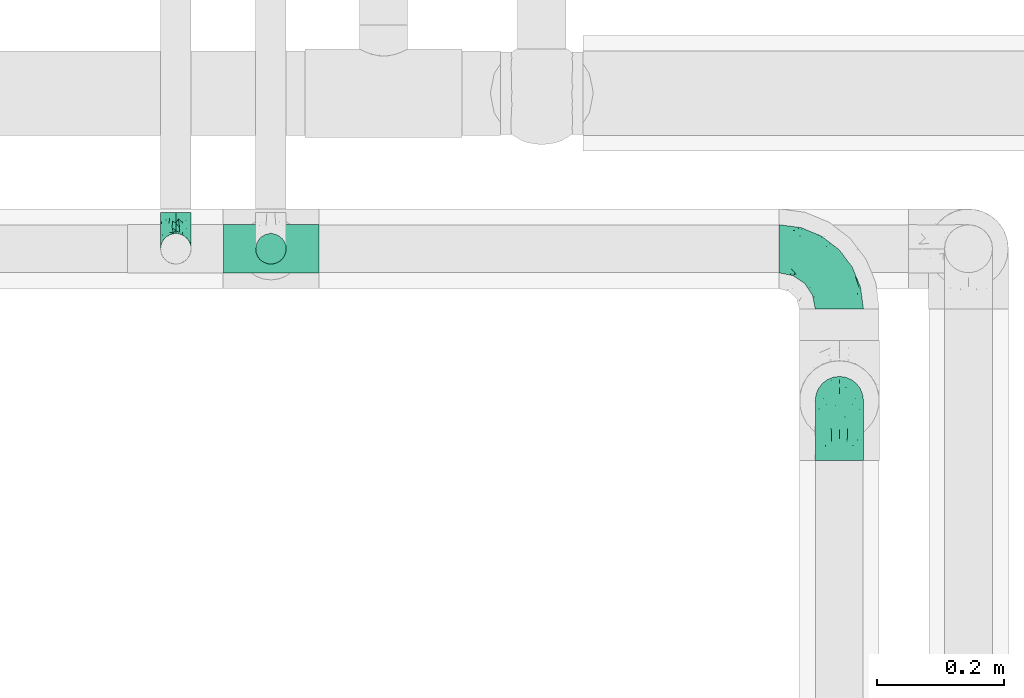
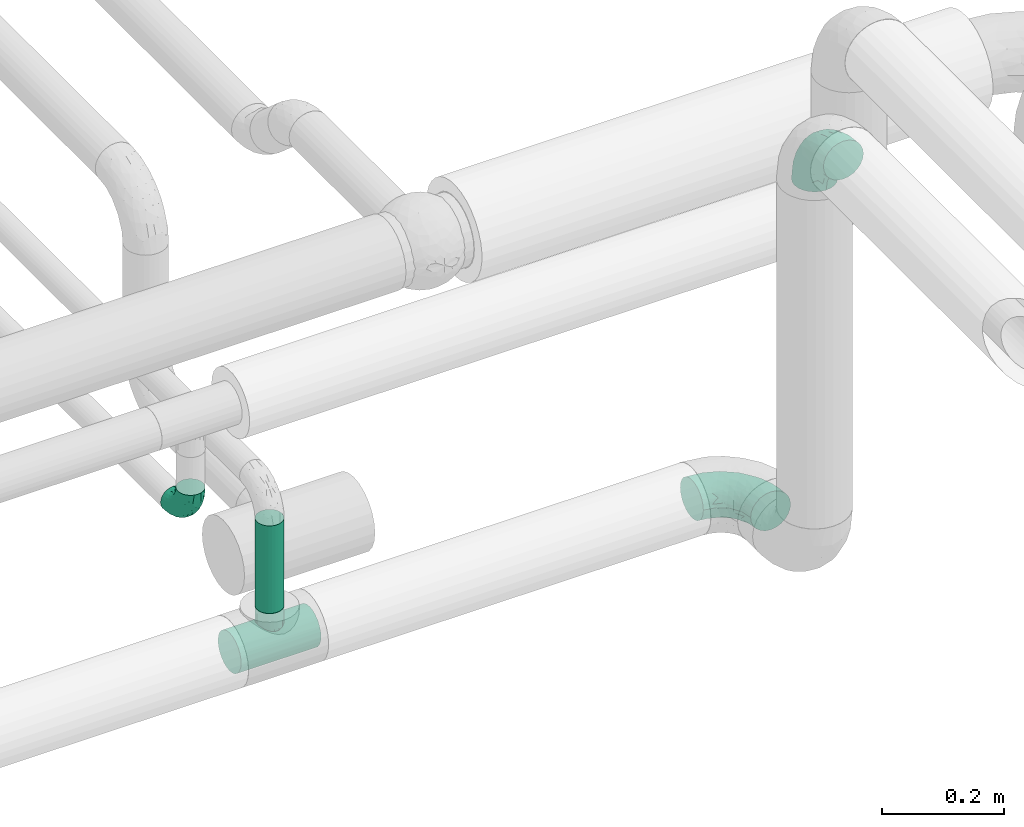
# One storey, part 557 of 827: 4 flow fittings, 1 flow segment.
"""IFC2X3 building model written with IfcOpenShell, lengths in millimetres."""

from ifc_helpers import new_model, entity, si_unit, converted_unit, derived_unit, direction, frame, origin, origin_2d_with_axis, place, context, subcontext, project, spatial, circle, extrude, faceted_brep, source, transform, mapped, material, type_object, type_shapes, element, save


model = new_model("IFC2X3")

# Units and contexts
model_context = context("Model", 3, precision=0.01, world=origin(), true_north=direction((6.12303176911189e-17, 1.0)))
body_context = subcontext(model_context, "Body", "Model", "MODEL_VIEW")
ifc_project = project(units=[si_unit("LENGTHUNIT", "METRE", prefix="MILLI"), si_unit("AREAUNIT", "SQUARE_METRE"), si_unit("VOLUMEUNIT", "CUBIC_METRE"), converted_unit("PLANEANGLEUNIT", "DEGREE", entity("IfcRatioMeasure", 0.0174532925199433), si_unit("PLANEANGLEUNIT", "RADIAN"), dimensions=[0, 0, 0, 0, 0, 0, 0]), si_unit("MASSUNIT", "GRAM", prefix="KILO"), derived_unit("MASSDENSITYUNIT", [(si_unit("MASSUNIT", "GRAM", prefix="KILO"), 1), (si_unit("LENGTHUNIT", "METRE"), -3)]), derived_unit("MOMENTOFINERTIAUNIT", [(si_unit("LENGTHUNIT", "METRE"), 4)]), si_unit("TIMEUNIT", "SECOND"), si_unit("FREQUENCYUNIT", "HERTZ"), si_unit("THERMODYNAMICTEMPERATUREUNIT", "DEGREE_CELSIUS"), derived_unit("THERMALTRANSMITTANCEUNIT", [(si_unit("MASSUNIT", "GRAM", prefix="KILO"), 1), (si_unit("THERMODYNAMICTEMPERATUREUNIT", "KELVIN"), -1), (si_unit("TIMEUNIT", "SECOND"), -3)]), derived_unit("VOLUMETRICFLOWRATEUNIT", [(si_unit("LENGTHUNIT", "METRE"), 3), (si_unit("TIMEUNIT", "SECOND"), -1)]), derived_unit("MASSFLOWRATEUNIT", [(si_unit("MASSUNIT", "GRAM", prefix="KILO"), 1), (si_unit("TIMEUNIT", "SECOND"), -1)]), derived_unit("ROTATIONALFREQUENCYUNIT", [(si_unit("TIMEUNIT", "SECOND"), -1)]), si_unit("ELECTRICCURRENTUNIT", "AMPERE"), si_unit("ELECTRICVOLTAGEUNIT", "VOLT"), si_unit("POWERUNIT", "WATT"), si_unit("FORCEUNIT", "NEWTON", prefix="KILO"), si_unit("ILLUMINANCEUNIT", "LUX"), si_unit("LUMINOUSFLUXUNIT", "LUMEN"), si_unit("LUMINOUSINTENSITYUNIT", "CANDELA"), derived_unit("USERDEFINED", [(si_unit("MASSUNIT", "GRAM", prefix="KILO"), -1), (si_unit("LENGTHUNIT", "METRE"), -2), (si_unit("TIMEUNIT", "SECOND"), 3), (si_unit("LUMINOUSFLUXUNIT", "LUMEN"), 1)]), derived_unit("LINEARVELOCITYUNIT", [(si_unit("LENGTHUNIT", "METRE"), 1), (si_unit("TIMEUNIT", "SECOND"), -1)]), si_unit("PRESSUREUNIT", "PASCAL"), derived_unit("USERDEFINED", [(si_unit("LENGTHUNIT", "METRE"), -2), (si_unit("MASSUNIT", "GRAM", prefix="KILO"), 1), (si_unit("TIMEUNIT", "SECOND"), -2)]), derived_unit("LINEARFORCEUNIT", [(si_unit("MASSUNIT", "GRAM", prefix="KILO"), 1), (si_unit("LENGTHUNIT", "METRE"), 1), (si_unit("TIMEUNIT", "SECOND"), -2), (si_unit("LENGTHUNIT", "METRE"), -1)]), derived_unit("PLANARFORCEUNIT", [(si_unit("MASSUNIT", "GRAM", prefix="KILO"), 1), (si_unit("LENGTHUNIT", "METRE"), 1), (si_unit("TIMEUNIT", "SECOND"), -2), (si_unit("LENGTHUNIT", "METRE"), -2)])], contexts=[model_context])

# Site, building, storey
site_placement = place(None, origin())
site = spatial("IfcSite", under=ifc_project, at=site_placement, CompositionType="ELEMENT")
building_placement = place(site_placement, origin())
building = spatial("IfcBuilding", under=site, at=building_placement, CompositionType="ELEMENT")
storey_placement = place(building_placement, frame((0.0, 0.0, 28200.0)))
storey = spatial("IfcBuildingStorey", under=building, at=storey_placement, Name="08", CompositionType="ELEMENT", Elevation=28200.0)

# Flow segment
pipe_segment_type = type_object("IfcPipeSegmentType", PredefinedType="NOTDEFINED")
flow_segment_placement = place(storey_placement, frame((25740.61, 12044.41, 2667.0)))
element("IfcFlowSegment", 1, at=flow_segment_placement, inside=storey, type_object=pipe_segment_type, context=body_context, shape_type="SweptSolid", body=[
    extrude(circle(Radius=24.0, at=origin_2d_with_axis()), frame((25.6, 25.6, 0.0)), (0.0, 0.0, 1.0), 175.999999999995),
])

# Flow fittings
ifc_material = material()
pipe_fitting_type_1 = type_object("IfcPipeFittingType", Name="ADSK_1", PredefinedType="NOTDEFINED", material=ifc_material)
shared_shape_1 = source(origin(), body_context, "Body", "Brep", [
    faceted_brep([(-76.0, 9.85, -36.75), (-76.0, 0.0, -38.05), (-76.0, -9.85, -36.75), (-76.0, -19.03, -32.95), (-76.0, -26.91, -26.91), (-76.0, -32.95, -19.03), (-76.0, -36.75, -9.85), (-76.0, -38.05, 0.0), (-76.0, -36.75, 9.85), (-76.0, -32.95, 19.02), (-76.0, -26.91, 26.91), (-76.0, -19.03, 32.95), (-76.0, -9.85, 36.75), (-76.0, 0.0, 38.05), (-76.0, 9.85, 36.75), (-76.0, 19.02, 32.95), (-76.0, 26.91, 26.91), (-76.0, 32.95, 19.02), (-76.0, 36.75, 9.85), (-76.0, 38.05, 0.0), (-76.0, 36.75, -9.85), (-76.0, 32.95, -19.03), (-76.0, 26.91, -26.91), (-76.0, 19.02, -32.95), (76.0, 26.91, -26.91), (76.0, 32.95, -19.03), (76.0, 36.75, -9.85), (76.0, 38.05, 0.0), (76.0, 36.75, 9.85), (76.0, 32.95, 19.02), (76.0, 26.91, 26.91), (76.0, 19.02, 32.95), (76.0, 9.85, 36.75), (76.0, 0.0, 38.05), (76.0, -9.85, 36.75), (76.0, -19.03, 32.95), (76.0, -26.91, 26.91), (76.0, -32.95, 19.02), (76.0, -36.75, 9.85), (76.0, -38.05, 0.0), (76.0, -36.75, -9.85), (76.0, -32.95, -19.03), (76.0, -26.91, -26.91), (76.0, -19.03, -32.95), (76.0, -9.85, -36.75), (76.0, 0.0, -38.05), (76.0, 9.85, -36.75), (76.0, 19.02, -32.95), (22.62, -37.1, 8.45), (23.39, -37.58, 4.22), (24.15, -38.05, 0.0), (18.42, -34.7, 15.61), (4.31, -29.72, 23.76), (12.18, -31.83, 20.86), (8.24, -30.77, 22.31), (-24.15, -38.05, 0.0), (-23.39, -37.58, 4.22), (-22.63, -37.1, 8.44), (-18.43, -34.7, 15.61), (-12.18, -31.83, 20.85), (-4.31, -29.72, 23.76), (0.0, -29.72, 23.76), (4.31, -29.72, -23.76), (12.18, -31.83, -20.86), (8.24, -30.77, -22.31), (18.42, -34.7, -15.61), (22.62, -37.1, -8.45), (23.39, -37.58, -4.22), (-4.31, -29.72, -23.76), (-12.18, -31.83, -20.85), (-18.43, -34.7, -15.61), (0.0, -29.72, -23.76), (-22.63, -37.1, -8.44), (-23.39, -37.58, -4.22), (0.0, -67.0, -24.15), (6.25, -67.0, -23.33), (12.08, -67.0, -20.91), (17.08, -67.0, -17.08), (20.91, -67.0, -12.08), (23.33, -67.0, -6.25), (24.15, -67.0, 0.0), (23.33, -67.0, 6.25), (20.91, -67.0, 12.07), (17.08, -67.0, 17.08), (12.08, -67.0, 20.91), (6.25, -67.0, 23.33), (0.0, -67.0, 24.15), (-6.25, -67.0, 23.33), (-12.07, -67.0, 20.91), (-17.08, -67.0, 17.08), (-20.91, -67.0, 12.07), (-23.33, -67.0, 6.25), (-24.15, -67.0, 0.0), (-23.33, -67.0, -6.25), (-20.91, -67.0, -12.08), (-17.08, -67.0, -17.08), (-12.07, -67.0, -20.91), (-6.25, -67.0, -23.33)], [[[0, 1, 2, 3, 4, 5, 6, 7, 8, 9, 10, 11, 12, 13, 14, 15, 16, 17, 18, 19, 20, 21, 22, 23]], [[24, 25, 26, 27, 28, 29, 30, 31, 32, 33, 34, 35, 36, 37, 38, 39, 40, 41, 42, 43, 44, 45, 46, 47]], [[39, 38, 48]], [[39, 48, 49, 50]], [[38, 51, 48]], [[37, 36, 52]], [[53, 51, 37]], [[37, 52, 54, 53]], [[36, 10, 52]], [[37, 51, 38]], [[7, 55, 56, 57]], [[8, 7, 57]], [[57, 58, 8]], [[59, 60, 9]], [[59, 9, 58]], [[9, 60, 10]], [[58, 9, 8]], [[10, 60, 61, 52]], [[36, 35, 11, 10]], [[13, 12, 34, 33]], [[12, 11, 35, 34]], [[14, 13, 33, 32]], [[29, 28, 18, 17]], [[16, 15, 31, 30]], [[17, 16, 30, 29]], [[32, 31, 15, 14]], [[19, 18, 28, 27]], [[26, 25, 21, 20]], [[25, 24, 22, 21]], [[27, 26, 20, 19]], [[45, 44, 2, 1]], [[0, 23, 47, 46]], [[1, 0, 46, 45]], [[24, 47, 23, 22]], [[3, 2, 44, 43]], [[43, 42, 4, 3]], [[42, 41, 62]], [[41, 63, 64, 62]], [[41, 65, 63]], [[42, 62, 4]], [[40, 39, 66]], [[66, 65, 40]], [[39, 50, 67, 66]], [[40, 65, 41]], [[68, 69, 5]], [[5, 4, 68]], [[69, 70, 5]], [[4, 62, 71, 68]], [[70, 72, 6]], [[72, 7, 6]], [[7, 72, 73, 55]], [[70, 6, 5]], [[74, 75, 76, 77, 78, 79, 80, 81, 82, 83, 84, 85, 86, 87, 88, 89, 90, 91, 92, 93, 94, 95, 96, 97]], [[56, 92, 91]], [[86, 60, 87]], [[59, 89, 88]], [[84, 54, 85]], [[49, 80, 50]], [[59, 88, 87]], [[49, 48, 81]], [[91, 57, 56]], [[55, 92, 56]], [[57, 91, 90]], [[57, 90, 58]], [[89, 58, 90]], [[89, 59, 58]], [[87, 60, 59]], [[86, 52, 61, 60]], [[84, 53, 54]], [[83, 53, 84]], [[48, 82, 81]], [[83, 82, 51]], [[52, 86, 85]], [[54, 52, 85]], [[53, 83, 51]], [[51, 82, 48]], [[80, 49, 81]], [[79, 67, 80]], [[77, 65, 78]], [[64, 76, 75]], [[79, 66, 67]], [[78, 66, 79]], [[63, 77, 76]], [[67, 50, 80]], [[66, 78, 65]], [[75, 62, 64]], [[63, 65, 77]], [[74, 68, 71, 62]], [[74, 62, 75]], [[73, 92, 55]], [[69, 97, 96]], [[73, 72, 93]], [[95, 69, 96]], [[72, 94, 93]], [[95, 94, 70]], [[68, 74, 97]], [[97, 69, 68]], [[69, 95, 70]], [[70, 94, 72]], [[92, 73, 93]], [[64, 63, 76]]]),
])
type_shapes(pipe_fitting_type_1, [shared_shape_1])
flow_fitting_1_placement = place(storey_placement, frame((25766.21, 12070.0, 2600.0), z_axis=(0.0, 1.0, 0.0), x_axis=(1.0, 0.0, 0.0)))
element("IfcFlowFitting", 2, at=flow_fitting_1_placement, inside=storey, type_object=pipe_fitting_type_1, material=ifc_material, Name="ADSK_1", ObjectType="ADSK_1", context=body_context, shape_type="MappedRepresentation", body=[
    mapped(shared_shape_1, transform((0.0, 0.0, 0.0), scale=1.0)),
])
pipe_fitting_type_2 = type_object("IfcPipeFittingType", Name="ADSK_1", PredefinedType="NOTDEFINED", material=ifc_material)
shared_shape_2 = source(origin(), body_context, "Body", "Brep", [
    faceted_brep([(-57.0, 12.07, -20.91), (-57.0, 6.25, -23.33), (-57.0, 0.0, -24.15), (-57.0, -6.25, -23.33), (-57.0, -12.08, -20.91), (-57.0, -17.08, -17.08), (-57.0, -20.91, -12.08), (-57.0, -23.33, -6.25), (-57.0, -24.15, 0.0), (-57.0, -23.33, 6.25), (-57.0, -20.91, 12.07), (-57.0, -17.08, 17.08), (-57.0, -12.08, 20.91), (-57.0, -6.25, 23.33), (-57.0, 0.0, 24.15), (-57.0, 6.25, 23.33), (-57.0, 12.07, 20.91), (-57.0, 17.08, 17.08), (-57.0, 20.91, 12.07), (-57.0, 23.33, 6.25), (-57.0, 24.15, 0.0), (-57.0, 23.33, -6.25), (-57.0, 20.91, -12.08), (-57.0, 17.08, -17.08), (0.0, 57.0, -24.15), (-6.25, 57.0, -23.33), (-12.07, 57.0, -20.91), (-17.08, 57.0, -17.08), (-20.91, 57.0, -12.08), (-23.33, 57.0, -6.25), (-24.15, 57.0, 0.0), (-23.33, 57.0, 6.25), (-20.91, 57.0, 12.07), (-17.08, 57.0, 17.08), (-12.07, 57.0, 20.91), (-6.25, 57.0, 23.33), (0.0, 57.0, 24.15), (6.25, 57.0, 23.33), (12.08, 57.0, 20.91), (17.08, 57.0, 17.08), (20.91, 57.0, 12.07), (23.33, 57.0, 6.25), (24.15, 57.0, 0.0), (23.33, 57.0, -6.25), (20.91, 57.0, -12.08), (17.08, 57.0, -17.08), (12.08, 57.0, -20.91), (6.25, 57.0, -23.33), (14.9, 21.14, 6.17), (13.61, 24.64, 12.48), (6.23, 8.95, 8.98), (-41.47, -21.06, 0.0), (-41.92, -18.38, 13.72), (-24.64, -13.61, 12.48), (-37.37, -13.24, 18.15), (-6.8, -4.93, 8.18), (-21.76, -15.19, 6.22), (-12.78, -9.18, 0.0), (-37.73, -20.51, 7.75), (-7.38, 7.38, 20.24), (-23.37, -4.26, 20.42), (-11.9, -3.19, 15.86), (-42.14, -8.7, 21.82), (13.24, 37.37, 18.15), (9.33, 23.53, 16.85), (4.26, 23.37, 20.42), (2.77, 10.92, 15.55), (-29.46, 0.91, 23.52), (-44.13, 20.56, 15.69), (-39.25, 26.33, 10.88), (-49.02, 22.92, 9.96), (-34.58, 23.87, 17.15), (-15.8, 6.8, 22.81), (-8.67, 20.47, 23.88), (-18.12, 12.9, 24.08), (-48.29, 14.92, 19.65), (-44.06, -2.85, 23.78), (-9.23, 48.95, 22.58), (-3.78, 42.74, 24.07), (-40.34, 4.26, 24.09), (-44.02, 26.14, 5.46), (-44.04, 9.88, 22.74), (-4.95, 16.87, 22.52), (-2.75, 1.43, 12.5), (-25.48, 40.98, 10.71), (20.51, 37.73, 7.75), (18.38, 41.92, 13.72), (8.7, 42.14, 21.82), (-25.95, -17.97, 0.0), (2.85, 44.06, 23.78), (21.06, 41.47, 0.0), (17.97, 25.95, 0.0), (-24.04, -9.27, 17.13), (-33.26, 33.26, 5.86), (-28.55, 40.57, 0.0), (-40.57, 28.55, 0.0), (-25.29, 47.19, 4.06), (-27.01, 31.1, 16.77), (-15.7, 43.95, 19.9), (-20.27, 45.22, 15.61), (-30.53, 31.98, 12.64), (-11.28, 38.33, 22.92), (-9.97, 27.88, 24.09), (-20.15, 30.26, 21.25), (-31.25, 11.75, 23.64), (-28.75, 7.23, 24.15), (-29.53, 18.06, 22.27), (-28.44, 24.21, 20.02), (-37.55, 17.7, 20.26), (-15.88, 29.25, 22.99), (-20.82, 20.82, 23.44), (-0.91, 29.46, 23.52), (-13.5, -7.67, 12.04), (1.49, 1.56, 5.16), (8.86, 10.35, 4.59), (0.38, -0.38, 0.0), (9.18, 12.78, 0.0), (-37.37, -13.24, -18.15), (8.86, 10.35, -4.59), (-45.22, 20.27, -15.61), (-43.95, 15.7, -19.9), (-38.33, 11.28, -22.92), (-48.95, 9.23, -22.58), (-47.19, 25.29, -4.06), (-33.26, 33.26, -5.86), (18.38, 41.92, -13.72), (-30.26, 20.15, -21.25), (2.85, 44.06, -23.78), (-4.26, 40.34, -24.09), (-40.98, 25.48, -10.71), (-41.92, -18.38, -13.72), (9.25, 23.5, -16.92), (4.26, 23.37, -20.42), (13.24, 37.37, -18.15), (-37.73, -20.51, -7.75), (-11.75, 31.25, -23.64), (-7.23, 28.75, -24.15), (-12.9, 18.12, -24.08), (8.7, 42.14, -21.82), (-44.06, -2.85, -23.78), (-6.8, 15.8, -22.81), (-20.47, 8.67, -23.88), (-24.64, -13.61, -12.48), (-42.74, 3.78, -24.07), (-18.06, 29.53, -22.27), (-24.21, 28.44, -20.02), (-27.88, 9.97, -24.09), (-31.1, 27.01, -16.77), (-26.14, 44.02, -5.46), (14.9, 21.14, -6.17), (20.51, 37.73, -7.75), (-9.88, 44.04, -22.74), (-20.56, 44.13, -15.69), (-21.76, -15.19, -6.22), (-13.5, -7.67, -12.04), (-24.14, -9.76, -16.74), (-11.9, -3.19, -15.86), (-14.92, 48.29, -19.65), (-23.37, -4.26, -20.42), (-0.91, 29.46, -23.52), (-26.33, 39.25, -10.88), (-23.87, 34.58, -17.15), (-42.14, -8.7, -21.82), (-22.92, 49.02, -9.96), (13.61, 24.64, -12.48), (-31.98, 30.53, -12.64), (-16.87, 4.95, -22.52), (-17.7, 37.55, -20.26), (-29.25, 15.88, -22.99), (-20.82, 20.82, -23.44), (-29.46, 0.91, -23.52), (-7.38, 7.38, -20.24), (2.77, 10.92, -15.55), (6.23, 8.95, -8.98), (-6.8, -4.93, -8.18), (-2.81, 1.41, -12.54), (1.49, 1.56, -5.16)], [[[0, 1, 2, 3, 4, 5, 6, 7, 8, 9, 10, 11, 12, 13, 14, 15, 16, 17, 18, 19, 20, 21, 22, 23]], [[24, 25, 26, 27, 28, 29, 30, 31, 32, 33, 34, 35, 36, 37, 38, 39, 40, 41, 42, 43, 44, 45, 46, 47]], [[48, 49, 50]], [[9, 8, 51]], [[52, 53, 54]], [[55, 56, 57]], [[10, 58, 52]], [[9, 58, 10]], [[59, 60, 61]], [[54, 12, 11]], [[54, 62, 12]], [[63, 39, 38]], [[64, 65, 66]], [[62, 60, 67]], [[68, 69, 70]], [[71, 69, 68]], [[72, 73, 74]], [[16, 75, 17]], [[13, 76, 14]], [[35, 77, 78]], [[14, 79, 15]], [[17, 68, 18]], [[14, 76, 79]], [[20, 19, 80]], [[70, 19, 18]], [[81, 15, 79]], [[15, 81, 16]], [[73, 72, 82]], [[66, 83, 50]], [[32, 31, 84]], [[85, 86, 49]], [[63, 87, 65]], [[56, 58, 88]], [[36, 89, 37]], [[85, 41, 40]], [[36, 35, 78]], [[90, 41, 85]], [[40, 39, 86]], [[12, 62, 13]], [[86, 85, 40]], [[48, 85, 49]], [[85, 91, 90]], [[87, 38, 37]], [[92, 60, 54]], [[80, 69, 93]], [[93, 94, 95]], [[10, 52, 11]], [[94, 96, 30]], [[97, 98, 99]], [[80, 93, 95]], [[100, 97, 84]], [[99, 98, 33]], [[101, 102, 78]], [[103, 101, 98]], [[96, 31, 30]], [[77, 98, 101]], [[77, 35, 34]], [[34, 33, 98]], [[9, 51, 58]], [[87, 63, 38]], [[104, 105, 74]], [[106, 103, 107]], [[106, 81, 104]], [[75, 68, 17]], [[108, 107, 71]], [[33, 32, 99]], [[109, 103, 110]], [[101, 109, 102]], [[89, 78, 111]], [[53, 52, 58]], [[54, 11, 52]], [[60, 62, 54]], [[88, 58, 51]], [[76, 62, 67]], [[53, 112, 92]], [[60, 59, 72]], [[39, 63, 86]], [[49, 86, 63]], [[89, 87, 37]], [[42, 41, 90]], [[111, 82, 65]], [[111, 65, 87]], [[65, 59, 66]], [[104, 81, 79]], [[75, 81, 108]], [[32, 84, 99]], [[97, 99, 84]], [[98, 97, 103]], [[106, 107, 108]], [[74, 102, 110]], [[111, 78, 102]], [[74, 110, 104]], [[74, 67, 72]], [[61, 92, 112]], [[66, 59, 61]], [[56, 53, 58]], [[66, 50, 49]], [[61, 112, 83]], [[66, 49, 64]], [[78, 89, 36]], [[87, 89, 111]], [[62, 76, 13]], [[79, 76, 67]], [[100, 93, 69]], [[96, 93, 84]], [[55, 113, 50]], [[113, 114, 50]], [[104, 79, 105]], [[106, 104, 110]], [[20, 80, 95]], [[85, 48, 91]], [[115, 114, 113]], [[116, 91, 48]], [[70, 80, 19]], [[93, 96, 94]], [[84, 31, 96]], [[103, 106, 110]], [[81, 106, 108]], [[103, 97, 107]], [[71, 107, 97]], [[71, 97, 100]], [[108, 71, 68]], [[79, 67, 105]], [[67, 74, 105]], [[115, 113, 57]], [[112, 56, 55]], [[56, 88, 57]], [[60, 72, 67]], [[82, 72, 59]], [[65, 82, 59]], [[82, 111, 73]], [[111, 102, 73]], [[102, 74, 73]], [[81, 75, 16]], [[68, 75, 108]], [[68, 70, 18]], [[80, 70, 69]], [[98, 77, 34]], [[78, 77, 101]], [[93, 100, 84]], [[71, 100, 69]], [[102, 109, 110]], [[101, 103, 109]], [[53, 92, 54]], [[61, 60, 92]], [[56, 112, 53]], [[83, 112, 55]], [[50, 83, 55]], [[61, 83, 66]], [[49, 63, 64]], [[65, 64, 63]], [[57, 113, 55]], [[114, 115, 116]], [[116, 48, 114]], [[48, 50, 114]], [[117, 5, 4]], [[116, 115, 118]], [[119, 120, 23]], [[121, 122, 120]], [[95, 123, 20]], [[0, 23, 120]], [[124, 95, 94]], [[125, 45, 44]], [[121, 120, 126]], [[24, 127, 128]], [[22, 21, 129]], [[0, 122, 1]], [[5, 117, 130]], [[131, 132, 133]], [[134, 88, 51]], [[135, 136, 137]], [[6, 5, 130]], [[46, 138, 47]], [[139, 3, 2]], [[140, 141, 137]], [[6, 134, 7]], [[134, 130, 142]], [[143, 2, 1]], [[144, 126, 145]], [[121, 146, 143]], [[147, 120, 119]], [[94, 148, 124]], [[149, 150, 91]], [[30, 29, 148]], [[151, 25, 128]], [[27, 152, 28]], [[134, 153, 88]], [[154, 155, 156]], [[27, 26, 157]], [[151, 26, 25]], [[155, 158, 156]], [[24, 47, 127]], [[1, 122, 143]], [[138, 132, 159]], [[160, 152, 161]], [[24, 128, 25]], [[46, 133, 138]], [[162, 117, 4]], [[148, 160, 124]], [[152, 160, 163]], [[154, 142, 155]], [[45, 125, 133]], [[133, 46, 45]], [[125, 164, 133]], [[51, 7, 134]], [[42, 90, 43]], [[165, 147, 129]], [[153, 134, 142]], [[43, 150, 44]], [[162, 4, 3]], [[141, 140, 166]], [[117, 162, 158]], [[163, 29, 28]], [[43, 90, 150]], [[123, 21, 20]], [[144, 151, 135]], [[157, 152, 27]], [[167, 145, 161]], [[23, 22, 119]], [[168, 126, 169]], [[121, 168, 146]], [[139, 143, 170]], [[142, 130, 117]], [[8, 7, 51]], [[134, 6, 130]], [[139, 162, 3]], [[170, 166, 158]], [[170, 158, 162]], [[158, 171, 156]], [[44, 150, 125]], [[91, 150, 90]], [[164, 125, 150]], [[132, 138, 133]], [[127, 138, 159]], [[131, 164, 172]], [[132, 171, 140]], [[135, 151, 128]], [[157, 151, 167]], [[22, 129, 119]], [[147, 119, 129]], [[120, 147, 126]], [[144, 145, 167]], [[137, 146, 169]], [[170, 143, 146]], [[137, 169, 135]], [[137, 159, 140]], [[171, 172, 156]], [[173, 174, 175]], [[156, 175, 154]], [[174, 57, 153]], [[132, 172, 171]], [[172, 164, 173]], [[143, 139, 2]], [[162, 139, 170]], [[138, 127, 47]], [[128, 127, 159]], [[165, 124, 160]], [[123, 124, 129]], [[149, 173, 164]], [[176, 174, 173]], [[135, 128, 136]], [[144, 135, 169]], [[150, 149, 164]], [[176, 118, 115]], [[149, 91, 116]], [[30, 148, 94]], [[163, 148, 29]], [[124, 123, 95]], [[129, 21, 123]], [[126, 144, 169]], [[151, 144, 167]], [[126, 147, 145]], [[161, 145, 147]], [[161, 147, 165]], [[167, 161, 152]], [[128, 159, 136]], [[159, 137, 136]], [[154, 153, 142]], [[132, 140, 159]], [[174, 176, 57]], [[57, 88, 153]], [[166, 140, 171]], [[158, 166, 171]], [[166, 170, 141]], [[170, 146, 141]], [[146, 137, 141]], [[151, 157, 26]], [[152, 157, 167]], [[152, 163, 28]], [[148, 163, 160]], [[120, 122, 0]], [[143, 122, 121]], [[124, 165, 129]], [[161, 165, 160]], [[146, 168, 169]], [[121, 126, 168]], [[142, 117, 155]], [[158, 155, 117]], [[175, 156, 172]], [[153, 154, 174]], [[173, 175, 172]], [[174, 154, 175]], [[164, 131, 133]], [[172, 132, 131]], [[176, 173, 118]], [[57, 176, 115]], [[173, 149, 118]], [[149, 116, 118]]]),
])
type_shapes(pipe_fitting_type_2, [shared_shape_2])
flow_fitting_2_placement = place(storey_placement, frame((25616.18, 12070.0, 2900.0), z_axis=(1.0, 0.0, 0.0), x_axis=(0.0, 0.0, -1.0)))
element("IfcFlowFitting", 3, at=flow_fitting_2_placement, inside=storey, type_object=pipe_fitting_type_2, material=ifc_material, Name="ADSK_1", ObjectType="ADSK_1", context=body_context, shape_type="MappedRepresentation", body=[
    mapped(shared_shape_2, transform((0.0, 0.0, 0.0), scale=1.0)),
])
pipe_fitting_type_3 = type_object("IfcPipeFittingType", Name="ADSK_1", PredefinedType="NOTDEFINED", material=ifc_material)
shared_shape_3 = source(origin(), body_context, "Body", "Brep", [
    faceted_brep([(-95.0, 19.02, -32.95), (-95.0, 9.85, -36.75), (-95.0, 0.0, -38.05), (-95.0, -9.85, -36.75), (-95.0, -19.03, -32.95), (-95.0, -26.91, -26.91), (-95.0, -32.95, -19.03), (-95.0, -36.75, -9.85), (-95.0, -38.05, 0.0), (-95.0, -36.75, 9.85), (-95.0, -32.95, 19.02), (-95.0, -26.91, 26.91), (-95.0, -19.03, 32.95), (-95.0, -9.85, 36.75), (-95.0, 0.0, 38.05), (-95.0, 9.85, 36.75), (-95.0, 19.02, 32.95), (-95.0, 26.91, 26.91), (-95.0, 32.95, 19.02), (-95.0, 36.75, 9.85), (-95.0, 38.05, 0.0), (-95.0, 36.75, -9.85), (-95.0, 32.95, -19.03), (-95.0, 26.91, -26.91), (0.0, 95.0, -38.05), (-9.85, 95.0, -36.75), (-19.02, 95.0, -32.95), (-26.91, 95.0, -26.91), (-32.95, 95.0, -19.03), (-36.75, 95.0, -9.85), (-38.05, 95.0, 0.0), (-36.75, 95.0, 9.85), (-32.95, 95.0, 19.02), (-26.91, 95.0, 26.91), (-19.02, 95.0, 32.95), (-9.85, 95.0, 36.75), (0.0, 95.0, 38.05), (9.85, 95.0, 36.75), (19.03, 95.0, 32.95), (26.91, 95.0, 26.91), (32.95, 95.0, 19.02), (36.75, 95.0, 9.85), (38.05, 95.0, 0.0), (36.75, 95.0, -9.85), (32.95, 95.0, -19.03), (26.91, 95.0, -26.91), (19.03, 95.0, -32.95), (9.85, 95.0, -36.75), (-7.99, -4.96, 6.3), (-0.92, 0.92, 0.0), (4.62, 8.1, 8.01), (-76.19, -35.57, 0.0), (-64.32, -32.32, 12.43), (20.51, 62.45, 28.68), (-60.56, -33.52, 0.0), (-70.4, -13.47, 34.42), (-39.61, -5.88, 32.32), (-49.6, 2.07, 37.1), (-70.34, -28.81, 21.71), (14.64, 40.81, 26.5), (5.88, 39.61, 32.32), (3.59, 20.77, 25.31), (-40.45, 68.06, 16.75), (-62.45, -20.51, 28.68), (-44.52, -26.87, 0.0), (-28.47, -20.22, 0.0), (-26.43, -17.83, 8.75), (-76.1, 39.63, 10.76), (-72.74, 37.58, 18.19), (-60.35, 46.18, 14.61), (-13.4, 13.4, 32.12), (-20.77, -3.59, 25.31), (-14.66, 81.47, 35.56), (-6.22, 71.26, 37.92), (-57.5, 42.48, 22.79), (-15.0, 34.74, 37.7), (-27.1, 12.08, 36.05), (-9.2, 28.81, 35.63), (-79.98, 23.7, 30.95), (-73.68, -4.3, 37.48), (-30.74, 21.67, 37.97), (-62.36, 47.59, 6.79), (-72.71, 32.83, 24.69), (-67.42, 7.02, 37.95), (-32.13, 75.27, 24.51), (-43.46, 51.47, 26.26), (-24.98, 73.15, 31.29), (20.59, 41.28, 19.85), (7.79, 16.09, 15.86), (-73.21, 42.39, 0.0), (-54.73, 54.73, 0.0), (-73.44, 15.79, 35.79), (-5.94, 4.32, 20.43), (28.81, 70.34, 21.71), (32.32, 64.32, 12.43), (-53.59, 26.2, 35.09), (-52.02, 19.31, 37.21), (21.38, 33.53, 10.34), (26.87, 44.52, 0.0), (-48.28, 12.14, 38.05), (4.3, 73.68, 37.48), (-44.08, -25.52, 12.79), (-41.28, -20.59, 19.85), (35.57, 76.19, 0.0), (-47.26, 54.3, 20.18), (-47.4, 61.99, 8.58), (-42.39, 73.21, 0.0), (-39.67, 78.86, 7.21), (-45.69, 36.84, 33.11), (-32.83, 50.13, 33.35), (13.47, 70.4, 34.42), (-18.25, 63.73, 36.07), (-40.63, -13.75, 27.22), (-16.63, 46.37, 37.95), (-53.47, 38.79, 28.59), (-26.07, 48.54, 36.15), (-34.51, 34.51, 36.86), (-2.07, 49.6, 37.1), (-22.79, -10.49, 19.23), (-61.73, 28.67, 31.87), (9.65, 14.7, 0.0), (20.22, 28.47, 0.0), (33.52, 60.56, 0.0), (-11.42, -5.44, 13.25), (-14.7, -9.65, 0.0), (-81.47, 14.66, -35.56), (-62.45, -20.51, -28.68), (-71.26, 6.22, -37.92), (-75.27, 32.13, -24.51), (-73.15, 24.98, -31.29), (13.47, 70.4, -34.42), (5.88, 39.61, -32.32), (-2.07, 49.6, -37.1), (-78.86, 39.67, -7.21), (-70.4, -13.47, -34.42), (-39.61, -5.88, -32.32), (-61.99, 47.4, -8.58), (32.32, 64.32, -12.43), (28.81, 70.34, -21.71), (-63.73, 18.25, -36.07), (-50.13, 32.83, -33.35), (4.3, 73.68, -37.48), (-7.02, 67.42, -37.95), (-39.63, 76.1, -10.76), (-46.18, 60.35, -14.61), (-47.59, 62.36, -6.79), (-64.32, -32.32, -12.43), (-26.2, 53.59, -35.09), (-15.79, 73.44, -35.79), (-19.31, 52.02, -37.21), (-37.58, 72.74, -18.19), (-70.34, -28.81, -21.71), (-42.48, 57.5, -22.79), (-38.79, 53.47, -28.59), (-51.47, 43.46, -26.26), (-32.83, 72.71, -24.69), (-46.37, 16.63, -37.95), (-73.68, -4.3, -37.48), (-41.28, -20.59, -19.85), (-44.08, -25.52, -12.79), (13.75, 40.63, -27.22), (20.51, 62.45, -28.68), (-68.06, 40.45, -16.75), (-54.3, 47.26, -20.18), (-12.14, 48.28, -38.05), (-21.67, 30.74, -37.97), (-36.84, 45.69, -33.11), (-11.42, -5.44, -13.25), (7.79, 16.09, -15.86), (4.62, 8.1, -8.01), (-23.7, 79.98, -30.95), (-26.43, -17.83, -8.75), (-7.99, -4.96, -6.3), (-40.81, -14.64, -26.5), (-20.77, -3.59, -25.31), (-34.74, 15.0, -37.7), (-12.08, 27.1, -36.05), (-28.81, 9.2, -35.63), (-22.79, -10.49, -19.23), (21.38, 33.53, -10.34), (20.59, 41.28, -19.85), (-48.54, 26.07, -36.15), (-49.6, 2.07, -37.1), (-13.4, 13.4, -32.12), (3.59, 20.77, -25.31), (-28.67, 61.73, -31.87), (-34.51, 34.51, -36.86), (-5.94, 4.32, -20.43)], [[[0, 1, 2, 3, 4, 5, 6, 7, 8, 9, 10, 11, 12, 13, 14, 15, 16, 17, 18, 19, 20, 21, 22, 23]], [[24, 25, 26, 27, 28, 29, 30, 31, 32, 33, 34, 35, 36, 37, 38, 39, 40, 41, 42, 43, 44, 45, 46, 47]], [[48, 49, 50]], [[51, 52, 9]], [[53, 39, 38]], [[9, 52, 10]], [[54, 52, 51]], [[55, 56, 57]], [[11, 10, 58]], [[59, 60, 61]], [[32, 31, 62]], [[63, 12, 11]], [[63, 55, 12]], [[64, 65, 66]], [[67, 68, 69]], [[70, 56, 71]], [[35, 72, 73]], [[69, 68, 74]], [[75, 76, 77]], [[16, 78, 17]], [[13, 79, 14]], [[76, 75, 80]], [[67, 69, 81]], [[18, 17, 82]], [[14, 79, 83]], [[20, 19, 67]], [[84, 85, 86]], [[87, 61, 88]], [[89, 81, 90]], [[18, 82, 68]], [[15, 91, 16]], [[14, 83, 15]], [[71, 92, 61]], [[17, 78, 82]], [[93, 87, 94]], [[95, 91, 96]], [[97, 98, 94]], [[86, 72, 34]], [[96, 99, 80]], [[37, 36, 100]], [[40, 39, 93]], [[40, 94, 41]], [[64, 66, 101]], [[93, 94, 40]], [[58, 102, 63]], [[94, 103, 41]], [[94, 87, 97]], [[104, 69, 74]], [[34, 33, 86]], [[105, 69, 104]], [[52, 58, 10]], [[106, 107, 30]], [[108, 109, 85]], [[105, 106, 90]], [[53, 110, 60]], [[86, 111, 72]], [[86, 109, 111]], [[33, 84, 86]], [[12, 55, 13]], [[112, 56, 63]], [[110, 38, 37]], [[34, 72, 35]], [[36, 35, 73]], [[111, 113, 73]], [[105, 107, 106]], [[110, 53, 38]], [[74, 114, 85]], [[91, 15, 83]], [[105, 90, 81]], [[107, 62, 31]], [[33, 32, 84]], [[115, 109, 116]], [[111, 115, 113]], [[100, 73, 117]], [[56, 55, 63]], [[79, 55, 57]], [[102, 118, 112]], [[56, 70, 76]], [[100, 110, 37]], [[117, 77, 60]], [[117, 60, 110]], [[60, 70, 61]], [[58, 52, 101]], [[63, 11, 58]], [[39, 53, 93]], [[87, 93, 53]], [[96, 91, 83]], [[78, 91, 119]], [[32, 62, 84]], [[84, 62, 104]], [[86, 85, 109]], [[85, 114, 108]], [[80, 113, 116]], [[117, 73, 113]], [[80, 116, 96]], [[80, 57, 76]], [[71, 112, 118]], [[61, 87, 59]], [[62, 107, 105]], [[97, 120, 121]], [[70, 71, 61]], [[71, 118, 92]], [[73, 100, 36]], [[110, 100, 117]], [[55, 79, 13]], [[83, 79, 57]], [[96, 83, 99]], [[116, 108, 95]], [[50, 97, 88]], [[97, 87, 88]], [[50, 49, 120]], [[122, 94, 98]], [[89, 20, 67]], [[105, 81, 69]], [[89, 67, 81]], [[68, 19, 18]], [[68, 67, 19]], [[74, 68, 82]], [[114, 82, 119]], [[74, 85, 104]], [[82, 114, 74]], [[114, 119, 108]], [[95, 108, 119]], [[116, 109, 108]], [[123, 48, 50]], [[97, 50, 120]], [[123, 50, 88]], [[91, 95, 119]], [[116, 95, 96]], [[84, 104, 85]], [[104, 62, 105]], [[83, 57, 99]], [[57, 80, 99]], [[66, 48, 123]], [[66, 124, 48]], [[118, 66, 123]], [[124, 66, 65]], [[66, 118, 101]], [[54, 64, 52]], [[124, 49, 48]], [[30, 107, 31]], [[91, 78, 16]], [[82, 78, 119]], [[56, 76, 57]], [[77, 76, 70]], [[60, 77, 70]], [[77, 117, 75]], [[117, 113, 75]], [[113, 80, 75]], [[9, 8, 51]], [[103, 94, 122]], [[103, 42, 41]], [[73, 72, 111]], [[113, 115, 116]], [[111, 109, 115]], [[102, 112, 63]], [[71, 56, 112]], [[118, 102, 101]], [[92, 123, 88]], [[123, 92, 118]], [[61, 92, 88]], [[87, 53, 59]], [[60, 59, 53]], [[97, 121, 98]], [[58, 101, 102]], [[64, 101, 52]], [[125, 1, 0]], [[126, 5, 4]], [[2, 1, 127]], [[1, 125, 127]], [[128, 129, 23]], [[130, 131, 132]], [[89, 133, 20]], [[126, 134, 135]], [[136, 89, 90]], [[137, 138, 44]], [[139, 129, 140]], [[24, 141, 142]], [[143, 144, 145]], [[125, 129, 139]], [[6, 146, 7]], [[147, 148, 149]], [[146, 51, 7]], [[143, 150, 144]], [[146, 6, 151]], [[152, 153, 154]], [[126, 4, 134]], [[0, 23, 129]], [[28, 155, 150]], [[43, 42, 103]], [[54, 146, 64]], [[139, 156, 127]], [[157, 3, 2]], [[151, 158, 159]], [[160, 131, 161]], [[22, 21, 162]], [[136, 144, 163]], [[149, 164, 165]], [[24, 142, 25]], [[166, 140, 154]], [[154, 129, 128]], [[143, 30, 29]], [[167, 168, 169]], [[155, 28, 27]], [[26, 170, 27]], [[171, 167, 172]], [[26, 25, 148]], [[27, 170, 155]], [[173, 135, 174]], [[144, 150, 152]], [[175, 176, 177]], [[24, 47, 141]], [[45, 161, 46]], [[148, 25, 142]], [[176, 175, 165]], [[64, 159, 171]], [[138, 45, 44]], [[130, 46, 161]], [[137, 44, 43]], [[178, 159, 158]], [[137, 103, 122]], [[163, 144, 152]], [[136, 133, 89]], [[103, 137, 43]], [[6, 5, 151]], [[178, 158, 173]], [[134, 4, 3]], [[178, 173, 174]], [[137, 98, 179]], [[145, 90, 106]], [[138, 180, 161]], [[46, 130, 47]], [[136, 90, 145]], [[133, 162, 21]], [[23, 22, 128]], [[139, 140, 181]], [[139, 181, 156]], [[157, 127, 182]], [[157, 134, 3]], [[182, 177, 135]], [[182, 135, 134]], [[135, 183, 174]], [[131, 130, 161]], [[141, 130, 132]], [[160, 180, 184]], [[131, 183, 176]], [[5, 126, 151]], [[158, 151, 126]], [[180, 138, 137]], [[161, 45, 138]], [[149, 148, 142]], [[170, 148, 185]], [[22, 162, 128]], [[128, 162, 163]], [[129, 154, 140]], [[154, 153, 166]], [[165, 156, 186]], [[182, 127, 156]], [[165, 186, 149]], [[165, 132, 176]], [[131, 184, 183]], [[187, 167, 178]], [[184, 168, 187]], [[167, 169, 172]], [[184, 180, 168]], [[174, 183, 184]], [[127, 157, 2]], [[134, 157, 182]], [[130, 141, 47]], [[142, 141, 132]], [[149, 142, 164]], [[186, 166, 147]], [[180, 179, 168]], [[169, 179, 120]], [[137, 179, 180]], [[179, 121, 120]], [[106, 30, 143]], [[136, 145, 144]], [[106, 143, 145]], [[150, 29, 28]], [[150, 143, 29]], [[152, 150, 155]], [[153, 155, 185]], [[152, 154, 163]], [[155, 153, 152]], [[153, 185, 166]], [[147, 166, 185]], [[186, 140, 166]], [[169, 120, 49]], [[169, 49, 172]], [[179, 169, 168]], [[148, 147, 185]], [[186, 147, 149]], [[128, 163, 154]], [[163, 162, 136]], [[142, 132, 164]], [[132, 165, 164]], [[171, 124, 65]], [[124, 171, 172]], [[64, 146, 159]], [[171, 159, 178]], [[171, 65, 64]], [[172, 49, 124]], [[162, 133, 136]], [[20, 133, 21]], [[148, 170, 26]], [[155, 170, 185]], [[131, 176, 132]], [[177, 176, 183]], [[135, 177, 183]], [[177, 182, 175]], [[182, 156, 175]], [[156, 165, 175]], [[51, 146, 54]], [[51, 8, 7]], [[129, 125, 0]], [[127, 125, 139]], [[140, 186, 181]], [[156, 181, 186]], [[158, 126, 173]], [[135, 173, 126]], [[187, 178, 174]], [[171, 178, 167]], [[184, 187, 174]], [[167, 187, 168]], [[180, 160, 161]], [[184, 131, 160]], [[98, 137, 122]], [[98, 121, 179]], [[151, 159, 146]]]),
])
type_shapes(pipe_fitting_type_3, [shared_shape_3])
for number, where, z_axis, x_axis, name in (
    (4, (26663.64, 11830.46, 3450.0), (-1.0, 0.0, 0.0), (0.0, 1.0, 0.0), "ADSK_1"),
    (5, (26663.64, 12070.0, 2600.0), (0.0, 0.0, 1.0), (0.0, 1.0, 0.0), "ADSK_1"),
):
    element("IfcFlowFitting", number, at=place(storey_placement, frame(where, z_axis=z_axis, x_axis=x_axis)), inside=storey, type_object=pipe_fitting_type_3, material=ifc_material, Name=name, ObjectType="ADSK_1", context=body_context, shape_type="MappedRepresentation", body=[
        mapped(shared_shape_3, transform((0.0, 0.0, 0.0), scale=1.0)),
    ])

save(model, "model.ifc")
